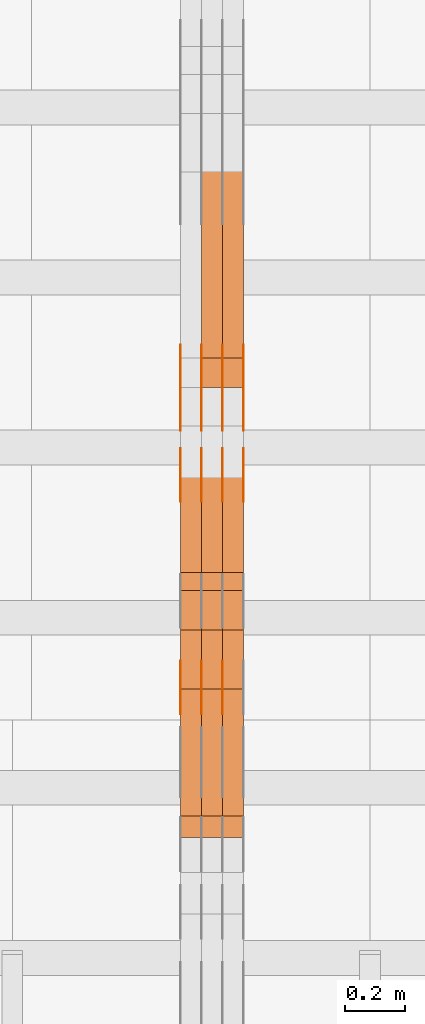
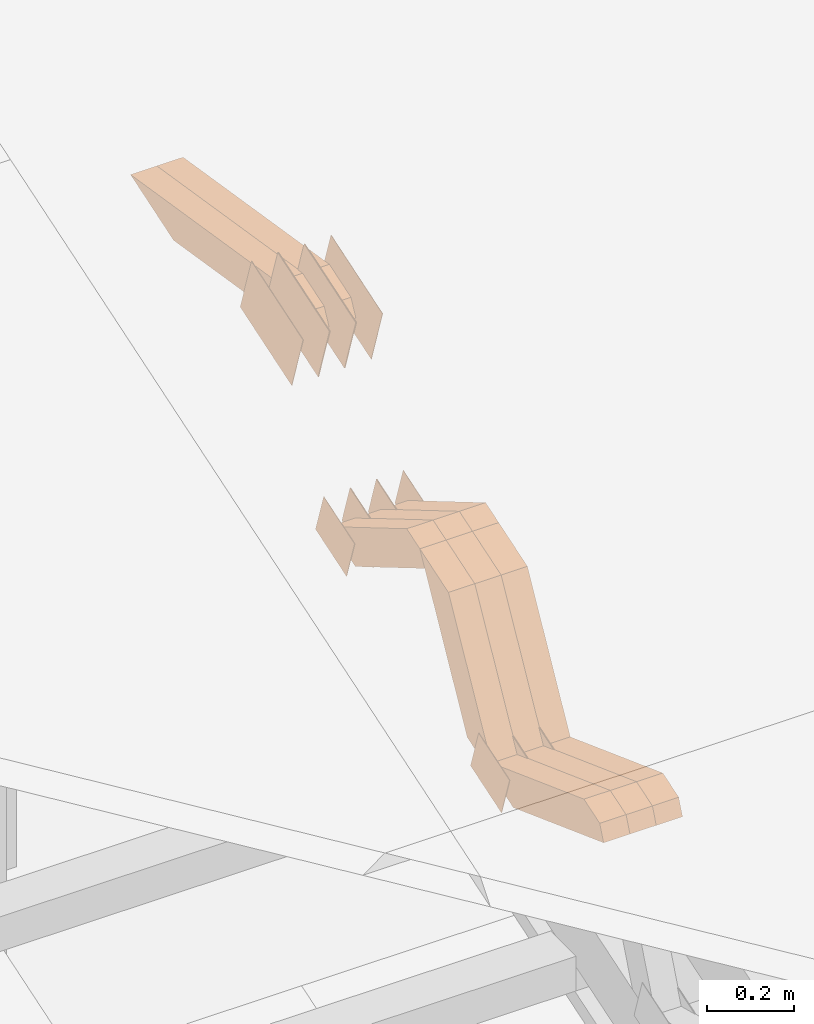
# One storey, part 52 of 385: 28 proxies.
"""IFC2X3 building model written with IfcOpenShell, lengths in millimetres."""

from ifc_helpers import new_model, entity, si_unit, converted_unit, derived_unit, direction, frame, origin, place, context, subcontext, project, spatial, polyline, outline, extrude, source, transform, mapped, material, type_object, type_shapes, element, save


model = new_model("IFC2X3")

# Units and contexts
model_context = context("Model", 3, precision=0.01, world=origin(), true_north=direction((6.12303176911189e-17, 1.0)))
body_context = subcontext(model_context, "Body", "Model", "MODEL_VIEW")
ifc_project = project(units=[si_unit("LENGTHUNIT", "METRE", prefix="MILLI"), si_unit("AREAUNIT", "SQUARE_METRE"), si_unit("VOLUMEUNIT", "CUBIC_METRE"), converted_unit("PLANEANGLEUNIT", "DEGREE", entity("IfcRatioMeasure", 0.0174532925199433), si_unit("PLANEANGLEUNIT", "RADIAN"), dimensions=[0, 0, 0, 0, 0, 0, 0]), si_unit("MASSUNIT", "GRAM", prefix="KILO"), derived_unit("MASSDENSITYUNIT", [(si_unit("MASSUNIT", "GRAM", prefix="KILO"), 1), (si_unit("LENGTHUNIT", "METRE"), -3)]), si_unit("TIMEUNIT", "SECOND"), si_unit("FREQUENCYUNIT", "HERTZ"), si_unit("THERMODYNAMICTEMPERATUREUNIT", "DEGREE_CELSIUS"), derived_unit("THERMALTRANSMITTANCEUNIT", [(si_unit("MASSUNIT", "GRAM", prefix="KILO"), 1), (si_unit("THERMODYNAMICTEMPERATUREUNIT", "KELVIN"), -1), (si_unit("TIMEUNIT", "SECOND"), -3)]), derived_unit("VOLUMETRICFLOWRATEUNIT", [(si_unit("LENGTHUNIT", "METRE"), 3), (si_unit("TIMEUNIT", "SECOND"), -1)]), si_unit("ELECTRICCURRENTUNIT", "AMPERE"), si_unit("ELECTRICVOLTAGEUNIT", "VOLT"), si_unit("POWERUNIT", "WATT"), si_unit("FORCEUNIT", "NEWTON", prefix="KILO"), si_unit("ILLUMINANCEUNIT", "LUX"), si_unit("LUMINOUSFLUXUNIT", "LUMEN"), si_unit("LUMINOUSINTENSITYUNIT", "CANDELA"), derived_unit("USERDEFINED", [(si_unit("MASSUNIT", "GRAM", prefix="KILO"), -1), (si_unit("LENGTHUNIT", "METRE"), -2), (si_unit("TIMEUNIT", "SECOND"), 3), (si_unit("LUMINOUSFLUXUNIT", "LUMEN"), 1)]), derived_unit("LINEARVELOCITYUNIT", [(si_unit("LENGTHUNIT", "METRE"), 1), (si_unit("TIMEUNIT", "SECOND"), -1)]), si_unit("PRESSUREUNIT", "PASCAL"), derived_unit("USERDEFINED", [(si_unit("LENGTHUNIT", "METRE"), -2), (si_unit("MASSUNIT", "GRAM", prefix="KILO"), 1), (si_unit("TIMEUNIT", "SECOND"), -2)])], contexts=[model_context])

# Site, building, storey
site_placement = place(None, origin())
site = spatial("IfcSite", under=ifc_project, at=site_placement, CompositionType="ELEMENT")
building_placement = place(site_placement, origin())
building = spatial("IfcBuilding", under=site, at=building_placement, CompositionType="ELEMENT")
storey_placement = place(building_placement, origin())
storey = spatial("IfcBuildingStorey", under=building, at=storey_placement, Name="Default", CompositionType="ELEMENT", Elevation=0.0)

# Proxies
ifc_material_1 = material(Name="IfcSurfaceStyle #106813")
building_element_proxy_type_1 = type_object("IfcBuildingElementProxyType", PredefinedType="NOTDEFINED", material=ifc_material_1)
shared_shape_1 = source(origin(), body_context, "Body", "SweptSolid", [
    extrude(outline(polyline([(-75.0008041947458, -59.9996998629349), (75.0007893252423, -59.9996998629349), (75.0008041947458, 59.9996998629349), (-75.0007893252423, 59.9996998629349), (-75.0008041947458, -59.9996998629349)])), frame((75.0008041947458, 60.0002282421692, 0.0), z_axis=(0.0, 0.0, 1.0), x_axis=(-1.0, 0.0, 0.0)), (0.0, 0.0, 1.0), 1.3),
])
type_shapes(building_element_proxy_type_1, [shared_shape_1])
proxy_1_placement = place(building_placement, frame((6315.0, 9291.048828125, 2194.94482421875), z_axis=(-1.0, 0.0, 0.0), x_axis=(0.0, 0.951056516295124, 0.309016994375039)))
element("IfcBuildingElementProxy", 1, at=proxy_1_placement, inside=storey, type_object=building_element_proxy_type_1, material=ifc_material_1, context=body_context, shape_type="MappedRepresentation", body=[
    mapped(shared_shape_1, transform((0.0, 0.0, 0.0), scale=1.0)),
])
ifc_material_2 = material(Name="IfcSurfaceStyle #106756")
building_element_proxy_type_2 = type_object("IfcBuildingElementProxyType", PredefinedType="NOTDEFINED", material=ifc_material_2)
shared_shape_2 = source(origin(), body_context, "Body", "SweptSolid", [
    extrude(outline(polyline([(-75.0008041947458, -59.9996998629349), (75.0007893252423, -59.9996998629349), (75.0008041947458, 59.9996998629349), (-75.0007893252423, 59.9996998629349), (-75.0008041947458, -59.9996998629349)])), frame((75.0008041947458, 60.0002282421692, 0.0), z_axis=(0.0, 0.0, 1.0), x_axis=(-1.0, 0.0, 0.0)), (0.0, 0.0, 1.0), 1.3),
])
type_shapes(building_element_proxy_type_2, [shared_shape_2])
proxy_2_placement = place(building_placement, frame((6316.29999999999, 9291.048828125, 2194.94482421875), z_axis=(-1.0, 0.0, 0.0), x_axis=(0.0, 0.951056516295124, 0.309016994375039)))
element("IfcBuildingElementProxy", 2, at=proxy_2_placement, inside=storey, type_object=building_element_proxy_type_2, material=ifc_material_2, context=body_context, shape_type="MappedRepresentation", body=[
    mapped(shared_shape_2, transform((0.0, 0.0, 0.0), scale=1.0)),
])
ifc_material_3 = material(Name="IfcSurfaceStyle #106699")
building_element_proxy_type_3 = type_object("IfcBuildingElementProxyType", PredefinedType="NOTDEFINED", material=ifc_material_3)
shared_shape_3 = source(origin(), body_context, "Body", "SweptSolid", [
    extrude(outline(polyline([(-75.0008041947458, -59.9996998629349), (75.0007893252423, -59.9996998629349), (75.0008041947458, 59.9996998629349), (-75.0007893252423, 59.9996998629349), (-75.0008041947458, -59.9996998629349)])), frame((75.0008041947458, 60.0002282421692, 0.0), z_axis=(0.0, 0.0, 1.0), x_axis=(-1.0, 0.0, 0.0)), (0.0, 0.0, 1.0), 1.29999999999999),
])
type_shapes(building_element_proxy_type_3, [shared_shape_3])
proxy_3_placement = place(building_placement, frame((6245.0, 9291.048828125, 2194.94482421875), z_axis=(-1.0, 0.0, 0.0), x_axis=(0.0, 0.951056516295124, 0.309016994375039)))
element("IfcBuildingElementProxy", 3, at=proxy_3_placement, inside=storey, type_object=building_element_proxy_type_3, material=ifc_material_3, context=body_context, shape_type="MappedRepresentation", body=[
    mapped(shared_shape_3, transform((0.0, 0.0, 0.0), scale=1.0)),
])
ifc_material_4 = material(Name="IfcSurfaceStyle #106642")
building_element_proxy_type_4 = type_object("IfcBuildingElementProxyType", PredefinedType="NOTDEFINED", material=ifc_material_4)
shared_shape_4 = source(origin(), body_context, "Body", "SweptSolid", [
    extrude(outline(polyline([(-75.0008041947458, -59.9996998629349), (75.0007893252423, -59.9996998629349), (75.0008041947458, 59.9996998629349), (-75.0007893252423, 59.9996998629349), (-75.0008041947458, -59.9996998629349)])), frame((75.0008041947458, 60.0002282421692, 0.0), z_axis=(0.0, 0.0, 1.0), x_axis=(-1.0, 0.0, 0.0)), (0.0, 0.0, 1.0), 1.29999999999999),
])
type_shapes(building_element_proxy_type_4, [shared_shape_4])
proxy_4_placement = place(building_placement, frame((6246.29999999999, 9291.048828125, 2194.94482421875), z_axis=(-1.0, 0.0, 0.0), x_axis=(0.0, 0.951056516295124, 0.309016994375039)))
element("IfcBuildingElementProxy", 4, at=proxy_4_placement, inside=storey, type_object=building_element_proxy_type_4, material=ifc_material_4, context=body_context, shape_type="MappedRepresentation", body=[
    mapped(shared_shape_4, transform((0.0, 0.0, 0.0), scale=1.0)),
])
ifc_material_5 = material(Name="IfcSurfaceStyle #106585")
building_element_proxy_type_5 = type_object("IfcBuildingElementProxyType", PredefinedType="NOTDEFINED", material=ifc_material_5)
shared_shape_5 = source(origin(), body_context, "Body", "SweptSolid", [
    extrude(outline(polyline([(-75.0008041947458, -59.9996998629349), (75.0007893252423, -59.9996998629349), (75.0008041947458, 59.9996998629349), (-75.0007893252423, 59.9996998629349), (-75.0008041947458, -59.9996998629349)])), frame((75.0008041947458, 60.0002282421692, 0.0), z_axis=(0.0, 0.0, 1.0), x_axis=(-1.0, 0.0, 0.0)), (0.0, 0.0, 1.0), 1.29999999999999),
])
type_shapes(building_element_proxy_type_5, [shared_shape_5])
proxy_5_placement = place(building_placement, frame((6175.0, 9291.048828125, 2194.94482421875), z_axis=(-1.0, 0.0, 0.0), x_axis=(0.0, 0.951056516295124, 0.309016994375039)))
element("IfcBuildingElementProxy", 5, at=proxy_5_placement, inside=storey, type_object=building_element_proxy_type_5, material=ifc_material_5, context=body_context, shape_type="MappedRepresentation", body=[
    mapped(shared_shape_5, transform((0.0, 0.0, 0.0), scale=1.0)),
])
ifc_material_6 = material(Name="IfcSurfaceStyle #106528")
building_element_proxy_type_6 = type_object("IfcBuildingElementProxyType", PredefinedType="NOTDEFINED", material=ifc_material_6)
shared_shape_6 = source(origin(), body_context, "Body", "SweptSolid", [
    extrude(outline(polyline([(-124.999432723313, -83.9999457831645), (125.000177551971, -83.9999457831645), (124.999395001513, 83.9999457831646), (-125.000139830171, 83.9999457831645), (-124.999432723313, -83.9999457831645)])), frame((125.000177551971, 84.0001194377192, 0.0), z_axis=(0.0, 0.0, 1.0), x_axis=(-1.0, 0.0, 0.0)), (0.0, 0.0, 1.0), 1.3),
])
type_shapes(building_element_proxy_type_6, [shared_shape_6])
proxy_6_placement = place(building_placement, frame((6386.29999999999, 10242.0968435407, 2855.88278137571), z_axis=(-1.0, 0.0, 0.0), x_axis=(0.0, 0.951056516295154, 0.309016994374948)))
element("IfcBuildingElementProxy", 6, at=proxy_6_placement, inside=storey, type_object=building_element_proxy_type_6, material=ifc_material_6, context=body_context, shape_type="MappedRepresentation", body=[
    mapped(shared_shape_6, transform((0.0, 0.0, 0.0), scale=1.0)),
])
ifc_material_7 = material(Name="IfcSurfaceStyle #106471")
building_element_proxy_type_7 = type_object("IfcBuildingElementProxyType", PredefinedType="NOTDEFINED", material=ifc_material_7)
shared_shape_7 = source(origin(), body_context, "Body", "SweptSolid", [
    extrude(outline(polyline([(-124.999432723313, -83.9999457831645), (125.000177551971, -83.9999457831645), (124.999395001513, 83.9999457831646), (-125.000139830171, 83.9999457831645), (-124.999432723313, -83.9999457831645)])), frame((125.000177551971, 84.0001194377192, 0.0), z_axis=(0.0, 0.0, 1.0), x_axis=(-1.0, 0.0, 0.0)), (0.0, 0.0, 1.0), 1.3),
])
type_shapes(building_element_proxy_type_7, [shared_shape_7])
proxy_7_placement = place(building_placement, frame((6315.0, 10242.0968435407, 2855.88278137571), z_axis=(-1.0, 0.0, 0.0), x_axis=(0.0, 0.951056516295154, 0.309016994374948)))
element("IfcBuildingElementProxy", 7, at=proxy_7_placement, inside=storey, type_object=building_element_proxy_type_7, material=ifc_material_7, context=body_context, shape_type="MappedRepresentation", body=[
    mapped(shared_shape_7, transform((0.0, 0.0, 0.0), scale=1.0)),
])
ifc_material_8 = material(Name="IfcSurfaceStyle #106414")
building_element_proxy_type_8 = type_object("IfcBuildingElementProxyType", PredefinedType="NOTDEFINED", material=ifc_material_8)
shared_shape_8 = source(origin(), body_context, "Body", "SweptSolid", [
    extrude(outline(polyline([(-124.999432723313, -83.9999457831645), (125.000177551971, -83.9999457831645), (124.999395001513, 83.9999457831646), (-125.000139830171, 83.9999457831645), (-124.999432723313, -83.9999457831645)])), frame((125.000177551971, 84.0001194377192, 0.0), z_axis=(0.0, 0.0, 1.0), x_axis=(-1.0, 0.0, 0.0)), (0.0, 0.0, 1.0), 1.3),
])
type_shapes(building_element_proxy_type_8, [shared_shape_8])
proxy_8_placement = place(building_placement, frame((6316.29999999999, 10242.0968435407, 2855.88278137571), z_axis=(-1.0, 0.0, 0.0), x_axis=(0.0, 0.951056516295154, 0.309016994374948)))
element("IfcBuildingElementProxy", 8, at=proxy_8_placement, inside=storey, type_object=building_element_proxy_type_8, material=ifc_material_8, context=body_context, shape_type="MappedRepresentation", body=[
    mapped(shared_shape_8, transform((0.0, 0.0, 0.0), scale=1.0)),
])
ifc_material_9 = material(Name="IfcSurfaceStyle #106357")
building_element_proxy_type_9 = type_object("IfcBuildingElementProxyType", PredefinedType="NOTDEFINED", material=ifc_material_9)
shared_shape_9 = source(origin(), body_context, "Body", "SweptSolid", [
    extrude(outline(polyline([(-124.999432723313, -83.9999457831645), (125.000177551971, -83.9999457831645), (124.999395001513, 83.9999457831646), (-125.000139830171, 83.9999457831645), (-124.999432723313, -83.9999457831645)])), frame((125.000177551971, 84.0001194377192, 0.0), z_axis=(0.0, 0.0, 1.0), x_axis=(-1.0, 0.0, 0.0)), (0.0, 0.0, 1.0), 1.29999999999998),
])
type_shapes(building_element_proxy_type_9, [shared_shape_9])
proxy_9_placement = place(building_placement, frame((6245.0, 10242.0968435407, 2855.88278137571), z_axis=(-1.0, 0.0, 0.0), x_axis=(0.0, 0.951056516295154, 0.309016994374948)))
element("IfcBuildingElementProxy", 9, at=proxy_9_placement, inside=storey, type_object=building_element_proxy_type_9, material=ifc_material_9, context=body_context, shape_type="MappedRepresentation", body=[
    mapped(shared_shape_9, transform((0.0, 0.0, 0.0), scale=1.0)),
])
ifc_material_10 = material(Name="IfcSurfaceStyle #106300")
building_element_proxy_type_10 = type_object("IfcBuildingElementProxyType", PredefinedType="NOTDEFINED", material=ifc_material_10)
shared_shape_10 = source(origin(), body_context, "Body", "SweptSolid", [
    extrude(outline(polyline([(-124.999432723313, -83.9999457831645), (125.000177551971, -83.9999457831645), (124.999395001513, 83.9999457831646), (-125.000139830171, 83.9999457831645), (-124.999432723313, -83.9999457831645)])), frame((125.000177551971, 84.0001194377192, 0.0), z_axis=(0.0, 0.0, 1.0), x_axis=(-1.0, 0.0, 0.0)), (0.0, 0.0, 1.0), 1.29999999999998),
])
type_shapes(building_element_proxy_type_10, [shared_shape_10])
proxy_10_placement = place(building_placement, frame((6246.29999999999, 10242.0968435407, 2855.88278137571), z_axis=(-1.0, 0.0, 0.0), x_axis=(0.0, 0.951056516295154, 0.309016994374948)))
element("IfcBuildingElementProxy", 10, at=proxy_10_placement, inside=storey, type_object=building_element_proxy_type_10, material=ifc_material_10, context=body_context, shape_type="MappedRepresentation", body=[
    mapped(shared_shape_10, transform((0.0, 0.0, 0.0), scale=1.0)),
])
ifc_material_11 = material(Name="IfcSurfaceStyle #106243")
building_element_proxy_type_11 = type_object("IfcBuildingElementProxyType", PredefinedType="NOTDEFINED", material=ifc_material_11)
shared_shape_11 = source(origin(), body_context, "Body", "SweptSolid", [
    extrude(outline(polyline([(-124.999432723313, -83.9999457831645), (125.000177551971, -83.9999457831645), (124.999395001513, 83.9999457831646), (-125.000139830171, 83.9999457831645), (-124.999432723313, -83.9999457831645)])), frame((125.000177551971, 84.0001194377192, 0.0), z_axis=(0.0, 0.0, 1.0), x_axis=(-1.0, 0.0, 0.0)), (0.0, 0.0, 1.0), 1.29999999999998),
])
type_shapes(building_element_proxy_type_11, [shared_shape_11])
proxy_11_placement = place(building_placement, frame((6175.0, 10242.0968435407, 2855.88278137571), z_axis=(-1.0, 0.0, 0.0), x_axis=(0.0, 0.951056516295154, 0.309016994374948)))
element("IfcBuildingElementProxy", 11, at=proxy_11_placement, inside=storey, type_object=building_element_proxy_type_11, material=ifc_material_11, context=body_context, shape_type="MappedRepresentation", body=[
    mapped(shared_shape_11, transform((0.0, 0.0, 0.0), scale=1.0)),
])
ifc_material_12 = material(Name="IfcSurfaceStyle #104818")
building_element_proxy_type_12 = type_object("IfcBuildingElementProxyType", PredefinedType="NOTDEFINED", material=ifc_material_12)
shared_shape_12 = source(origin(), body_context, "Body", "SweptSolid", [
    extrude(outline(polyline([(-74.9998754286189, -60.0000016373433), (74.9998605591118, -60.0000016373433), (74.9998754286189, 60.0000016373433), (-74.9998605591118, 60.0000016373433), (-74.9998754286189, -60.0000016373433)])), frame((74.9999131819004, 60.0000016373433, 0.0), z_axis=(0.0, 0.0, 1.0), x_axis=(-1.0, 0.0, 0.0)), (0.0, 0.0, 1.0), 1.3),
])
type_shapes(building_element_proxy_type_12, [shared_shape_12])
proxy_12_placement = place(building_placement, frame((6386.29999999999, 10004.8612689908, 2426.87628052724), z_axis=(-1.0, 0.0, 0.0), x_axis=(0.0, 0.951056516295124, 0.309016994375039)))
element("IfcBuildingElementProxy", 12, at=proxy_12_placement, inside=storey, type_object=building_element_proxy_type_12, material=ifc_material_12, context=body_context, shape_type="MappedRepresentation", body=[
    mapped(shared_shape_12, transform((0.0, 0.0, 0.0), scale=1.0)),
])
ifc_material_13 = material(Name="IfcSurfaceStyle #104761")
building_element_proxy_type_13 = type_object("IfcBuildingElementProxyType", PredefinedType="NOTDEFINED", material=ifc_material_13)
shared_shape_13 = source(origin(), body_context, "Body", "SweptSolid", [
    extrude(outline(polyline([(-74.9998754286189, -60.0000016373433), (74.9998605591118, -60.0000016373433), (74.9998754286189, 60.0000016373433), (-74.9998605591118, 60.0000016373433), (-74.9998754286189, -60.0000016373433)])), frame((74.9999131819004, 60.0000016373433, 0.0), z_axis=(0.0, 0.0, 1.0), x_axis=(-1.0, 0.0, 0.0)), (0.0, 0.0, 1.0), 1.3),
])
type_shapes(building_element_proxy_type_13, [shared_shape_13])
proxy_13_placement = place(building_placement, frame((6315.0, 10004.8612689908, 2426.87628052724), z_axis=(-1.0, 0.0, 0.0), x_axis=(0.0, 0.951056516295124, 0.309016994375039)))
element("IfcBuildingElementProxy", 13, at=proxy_13_placement, inside=storey, type_object=building_element_proxy_type_13, material=ifc_material_13, context=body_context, shape_type="MappedRepresentation", body=[
    mapped(shared_shape_13, transform((0.0, 0.0, 0.0), scale=1.0)),
])
ifc_material_14 = material(Name="IfcSurfaceStyle #104704")
building_element_proxy_type_14 = type_object("IfcBuildingElementProxyType", PredefinedType="NOTDEFINED", material=ifc_material_14)
shared_shape_14 = source(origin(), body_context, "Body", "SweptSolid", [
    extrude(outline(polyline([(-74.9998754286189, -60.0000016373433), (74.9998605591118, -60.0000016373433), (74.9998754286189, 60.0000016373433), (-74.9998605591118, 60.0000016373433), (-74.9998754286189, -60.0000016373433)])), frame((74.9999131819004, 60.0000016373433, 0.0), z_axis=(0.0, 0.0, 1.0), x_axis=(-1.0, 0.0, 0.0)), (0.0, 0.0, 1.0), 1.3),
])
type_shapes(building_element_proxy_type_14, [shared_shape_14])
proxy_14_placement = place(building_placement, frame((6316.29999999999, 10004.8612689908, 2426.87628052724), z_axis=(-1.0, 0.0, 0.0), x_axis=(0.0, 0.951056516295124, 0.309016994375039)))
element("IfcBuildingElementProxy", 14, at=proxy_14_placement, inside=storey, type_object=building_element_proxy_type_14, material=ifc_material_14, context=body_context, shape_type="MappedRepresentation", body=[
    mapped(shared_shape_14, transform((0.0, 0.0, 0.0), scale=1.0)),
])
ifc_material_15 = material(Name="IfcSurfaceStyle #104647")
building_element_proxy_type_15 = type_object("IfcBuildingElementProxyType", PredefinedType="NOTDEFINED", material=ifc_material_15)
shared_shape_15 = source(origin(), body_context, "Body", "SweptSolid", [
    extrude(outline(polyline([(-74.9998754286189, -60.0000016373433), (74.9998605591118, -60.0000016373433), (74.9998754286189, 60.0000016373433), (-74.9998605591118, 60.0000016373433), (-74.9998754286189, -60.0000016373433)])), frame((74.9999131819004, 60.0000016373433, 0.0), z_axis=(0.0, 0.0, 1.0), x_axis=(-1.0, 0.0, 0.0)), (0.0, 0.0, 1.0), 1.29999999999999),
])
type_shapes(building_element_proxy_type_15, [shared_shape_15])
proxy_15_placement = place(building_placement, frame((6245.0, 10004.8612689908, 2426.87628052724), z_axis=(-1.0, 0.0, 0.0), x_axis=(0.0, 0.951056516295124, 0.309016994375039)))
element("IfcBuildingElementProxy", 15, at=proxy_15_placement, inside=storey, type_object=building_element_proxy_type_15, material=ifc_material_15, context=body_context, shape_type="MappedRepresentation", body=[
    mapped(shared_shape_15, transform((0.0, 0.0, 0.0), scale=1.0)),
])
ifc_material_16 = material(Name="IfcSurfaceStyle #104590")
building_element_proxy_type_16 = type_object("IfcBuildingElementProxyType", PredefinedType="NOTDEFINED", material=ifc_material_16)
shared_shape_16 = source(origin(), body_context, "Body", "SweptSolid", [
    extrude(outline(polyline([(-74.9998754286189, -60.0000016373433), (74.9998605591118, -60.0000016373433), (74.9998754286189, 60.0000016373433), (-74.9998605591118, 60.0000016373433), (-74.9998754286189, -60.0000016373433)])), frame((74.9999131819004, 60.0000016373433, 0.0), z_axis=(0.0, 0.0, 1.0), x_axis=(-1.0, 0.0, 0.0)), (0.0, 0.0, 1.0), 1.29999999999999),
])
type_shapes(building_element_proxy_type_16, [shared_shape_16])
proxy_16_placement = place(building_placement, frame((6246.29999999999, 10004.8612689908, 2426.87628052724), z_axis=(-1.0, 0.0, 0.0), x_axis=(0.0, 0.951056516295124, 0.309016994375039)))
element("IfcBuildingElementProxy", 16, at=proxy_16_placement, inside=storey, type_object=building_element_proxy_type_16, material=ifc_material_16, context=body_context, shape_type="MappedRepresentation", body=[
    mapped(shared_shape_16, transform((0.0, 0.0, 0.0), scale=1.0)),
])
ifc_material_17 = material(Name="IfcSurfaceStyle #104533")
building_element_proxy_type_17 = type_object("IfcBuildingElementProxyType", PredefinedType="NOTDEFINED", material=ifc_material_17)
shared_shape_17 = source(origin(), body_context, "Body", "SweptSolid", [
    extrude(outline(polyline([(-74.9998754286189, -60.0000016373433), (74.9998605591118, -60.0000016373433), (74.9998754286189, 60.0000016373433), (-74.9998605591118, 60.0000016373433), (-74.9998754286189, -60.0000016373433)])), frame((74.9999131819004, 60.0000016373433, 0.0), z_axis=(0.0, 0.0, 1.0), x_axis=(-1.0, 0.0, 0.0)), (0.0, 0.0, 1.0), 1.29999999999999),
])
type_shapes(building_element_proxy_type_17, [shared_shape_17])
proxy_17_placement = place(building_placement, frame((6175.0, 10004.8612689908, 2426.87628052724), z_axis=(-1.0, 0.0, 0.0), x_axis=(0.0, 0.951056516295124, 0.309016994375039)))
element("IfcBuildingElementProxy", 17, at=proxy_17_placement, inside=storey, type_object=building_element_proxy_type_17, material=ifc_material_17, context=body_context, shape_type="MappedRepresentation", body=[
    mapped(shared_shape_17, transform((0.0, 0.0, 0.0), scale=1.0)),
])
ifc_material_18 = material(Name="IfcSurfaceStyle #84496")
building_element_proxy_type_18 = type_object("IfcBuildingElementProxyType", Name="T1-W5 84494", PredefinedType="NOTDEFINED", material=ifc_material_18)
shared_shape_18 = source(origin(), body_context, "Body", "SweptSolid", [
    extrude(outline(polyline([(-301.214270081322, -47.5000783565111), (303.980395954293, -47.5000783565111), (288.664123931657, 0.000197935560590153), (195.704076557203, 47.4999793887309), (-487.134326361831, 47.4999793887309), (-301.214270081322, -47.5000783565111)])), frame((303.980395954293, 47.5001815410909, 0.0), z_axis=(0.0, 0.0, 1.0), x_axis=(-1.0, 0.0, 0.0)), (0.0, 0.0, 1.0), 70.0),
])
type_shapes(building_element_proxy_type_18, [shared_shape_18])
proxy_18_placement = place(building_placement, frame((6385.0, 10379.2051671398, 2863.91176079486), z_axis=(-1.0, 0.0, 0.0), x_axis=(0.0, 0.987508363398486, -0.1575665961365)))
element("IfcBuildingElementProxy", 18, at=proxy_18_placement, inside=storey, type_object=building_element_proxy_type_18, material=ifc_material_18, Name="T1-W5", context=body_context, shape_type="MappedRepresentation", body=[
    mapped(shared_shape_18, transform((0.0, 0.0, 0.0), scale=1.0)),
])
ifc_material_19 = material(Name="IfcSurfaceStyle #84430")
building_element_proxy_type_19 = type_object("IfcBuildingElementProxyType", Name="T1-W5 84428", PredefinedType="NOTDEFINED", material=ifc_material_19)
shared_shape_19 = source(origin(), body_context, "Body", "SweptSolid", [
    extrude(outline(polyline([(-301.214270081322, -47.5000783565111), (303.980395954293, -47.5000783565111), (288.664123931657, 0.000197935560590153), (195.704076557203, 47.4999793887309), (-487.134326361831, 47.4999793887309), (-301.214270081322, -47.5000783565111)])), frame((303.980395954293, 47.5001815410909, 0.0), z_axis=(0.0, 0.0, 1.0), x_axis=(-1.0, 0.0, 0.0)), (0.0, 0.0, 1.0), 70.0),
])
type_shapes(building_element_proxy_type_19, [shared_shape_19])
proxy_19_placement = place(building_placement, frame((6315.0, 10379.2051671398, 2863.91176079486), z_axis=(-1.0, 0.0, 0.0), x_axis=(0.0, 0.987508363398486, -0.1575665961365)))
element("IfcBuildingElementProxy", 19, at=proxy_19_placement, inside=storey, type_object=building_element_proxy_type_19, material=ifc_material_19, Name="T1-W5", context=body_context, shape_type="MappedRepresentation", body=[
    mapped(shared_shape_19, transform((0.0, 0.0, 0.0), scale=1.0)),
])
ifc_material_20 = material(Name="IfcSurfaceStyle #83704")
building_element_proxy_type_20 = type_object("IfcBuildingElementProxyType", Name="T1-W43 83702", PredefinedType="NOTDEFINED", material=ifc_material_20)
shared_shape_20 = source(origin(), body_context, "Body", "SweptSolid", [
    extrude(outline(polyline([(-198.159905426436, -47.4999961988362), (173.155878681738, -47.4999961988362), (174.585865234707, -0.00038778214839239), (132.582704932703, 47.5001900899104), (-282.164543422712, 47.5001900899104), (-198.159905426436, -47.4999961988362)])), frame((174.585865234707, 47.5001900899104, 0.0), z_axis=(0.0, 0.0, 1.0), x_axis=(-1.0, 0.0, 0.0)), (0.0, 0.0, 1.0), 70.0),
])
type_shapes(building_element_proxy_type_20, [shared_shape_20])
proxy_20_placement = place(building_placement, frame((6385.0, 9730.71877771152, 2634.4881681647), z_axis=(-1.0, 0.0, 0.0), x_axis=(0.0, 0.861495156633645, -0.507765787639115)))
element("IfcBuildingElementProxy", 20, at=proxy_20_placement, inside=storey, type_object=building_element_proxy_type_20, material=ifc_material_20, Name="T1-W43", context=body_context, shape_type="MappedRepresentation", body=[
    mapped(shared_shape_20, transform((0.0, 0.0, 0.0), scale=1.0)),
])
ifc_material_21 = material(Name="IfcSurfaceStyle #83638")
building_element_proxy_type_21 = type_object("IfcBuildingElementProxyType", Name="T1-W43 83636", PredefinedType="NOTDEFINED", material=ifc_material_21)
shared_shape_21 = source(origin(), body_context, "Body", "SweptSolid", [
    extrude(outline(polyline([(-198.159905426436, -47.4999961988362), (173.155878681738, -47.4999961988362), (174.585865234707, -0.00038778214839239), (132.582704932703, 47.5001900899104), (-282.164543422712, 47.5001900899104), (-198.159905426436, -47.4999961988362)])), frame((174.585865234707, 47.5001900899104, 0.0), z_axis=(0.0, 0.0, 1.0), x_axis=(-1.0, 0.0, 0.0)), (0.0, 0.0, 1.0), 70.0),
])
type_shapes(building_element_proxy_type_21, [shared_shape_21])
proxy_21_placement = place(building_placement, frame((6315.0, 9730.71877771152, 2634.4881681647), z_axis=(-1.0, 0.0, 0.0), x_axis=(0.0, 0.861495156633645, -0.507765787639115)))
element("IfcBuildingElementProxy", 21, at=proxy_21_placement, inside=storey, type_object=building_element_proxy_type_21, material=ifc_material_21, Name="T1-W43", context=body_context, shape_type="MappedRepresentation", body=[
    mapped(shared_shape_21, transform((0.0, 0.0, 0.0), scale=1.0)),
])
ifc_material_22 = material(Name="IfcSurfaceStyle #83572")
building_element_proxy_type_22 = type_object("IfcBuildingElementProxyType", Name="T1-W43 83570", PredefinedType="NOTDEFINED", material=ifc_material_22)
shared_shape_22 = source(origin(), body_context, "Body", "SweptSolid", [
    extrude(outline(polyline([(-198.159905426436, -47.4999961988362), (173.155878681738, -47.4999961988362), (174.585865234707, -0.00038778214839239), (132.582704932703, 47.5001900899104), (-282.164543422712, 47.5001900899104), (-198.159905426436, -47.4999961988362)])), frame((174.585865234707, 47.5001900899104, 0.0), z_axis=(0.0, 0.0, 1.0), x_axis=(-1.0, 0.0, 0.0)), (0.0, 0.0, 1.0), 70.0),
])
type_shapes(building_element_proxy_type_22, [shared_shape_22])
proxy_22_placement = place(building_placement, frame((6245.0, 9730.71877771152, 2634.4881681647), z_axis=(-1.0, 0.0, 0.0), x_axis=(0.0, 0.861495156633645, -0.507765787639115)))
element("IfcBuildingElementProxy", 22, at=proxy_22_placement, inside=storey, type_object=building_element_proxy_type_22, material=ifc_material_22, Name="T1-W43", context=body_context, shape_type="MappedRepresentation", body=[
    mapped(shared_shape_22, transform((0.0, 0.0, 0.0), scale=1.0)),
])
ifc_material_23 = material(Name="IfcSurfaceStyle #83308")
building_element_proxy_type_23 = type_object("IfcBuildingElementProxyType", Name="T1-W33 83306", PredefinedType="NOTDEFINED", material=ifc_material_23)
shared_shape_23 = source(origin(), body_context, "Body", "SweptSolid", [
    extrude(outline(polyline([(-314.173070820175, -47.4997758466969), (139.635944117881, -47.4997758466969), (190.204920608233, 0.000348187720347082), (197.369205310989, 47.5001702328475), (-213.036999216928, 47.4990332728259), (-314.173070820175, -47.4997758466969)])), frame((197.369205310989, 47.5001702328475, 0.0), z_axis=(0.0, 0.0, 1.0), x_axis=(-1.0, 0.0, 0.0)), (0.0, 0.0, 1.0), 70.0),
])
type_shapes(building_element_proxy_type_23, [shared_shape_23])
proxy_23_placement = place(building_placement, frame((6385.0, 9376.96875, 2191.01977539063), z_axis=(-1.0, 0.0, 0.0), x_axis=(0.0, 0.481632628948835, 0.876373214293907)))
element("IfcBuildingElementProxy", 23, at=proxy_23_placement, inside=storey, type_object=building_element_proxy_type_23, material=ifc_material_23, Name="T1-W33", context=body_context, shape_type="MappedRepresentation", body=[
    mapped(shared_shape_23, transform((0.0, 0.0, 0.0), scale=1.0)),
])
ifc_material_24 = material(Name="IfcSurfaceStyle #83242")
building_element_proxy_type_24 = type_object("IfcBuildingElementProxyType", Name="T1-W33 83240", PredefinedType="NOTDEFINED", material=ifc_material_24)
shared_shape_24 = source(origin(), body_context, "Body", "SweptSolid", [
    extrude(outline(polyline([(-314.173070820175, -47.4997758466969), (139.635944117881, -47.4997758466969), (190.204920608233, 0.000348187720347082), (197.369205310989, 47.5001702328475), (-213.036999216928, 47.4990332728259), (-314.173070820175, -47.4997758466969)])), frame((197.369205310989, 47.5001702328475, 0.0), z_axis=(0.0, 0.0, 1.0), x_axis=(-1.0, 0.0, 0.0)), (0.0, 0.0, 1.0), 70.0),
])
type_shapes(building_element_proxy_type_24, [shared_shape_24])
proxy_24_placement = place(building_placement, frame((6315.0, 9376.96875, 2191.01977539063), z_axis=(-1.0, 0.0, 0.0), x_axis=(0.0, 0.481632628948835, 0.876373214293907)))
element("IfcBuildingElementProxy", 24, at=proxy_24_placement, inside=storey, type_object=building_element_proxy_type_24, material=ifc_material_24, Name="T1-W33", context=body_context, shape_type="MappedRepresentation", body=[
    mapped(shared_shape_24, transform((0.0, 0.0, 0.0), scale=1.0)),
])
ifc_material_25 = material(Name="IfcSurfaceStyle #83176")
building_element_proxy_type_25 = type_object("IfcBuildingElementProxyType", Name="T1-W33 83174", PredefinedType="NOTDEFINED", material=ifc_material_25)
shared_shape_25 = source(origin(), body_context, "Body", "SweptSolid", [
    extrude(outline(polyline([(-314.173070820175, -47.4997758466969), (139.635944117881, -47.4997758466969), (190.204920608233, 0.000348187720347082), (197.369205310989, 47.5001702328475), (-213.036999216928, 47.4990332728259), (-314.173070820175, -47.4997758466969)])), frame((197.369205310989, 47.5001702328475, 0.0), z_axis=(0.0, 0.0, 1.0), x_axis=(-1.0, 0.0, 0.0)), (0.0, 0.0, 1.0), 70.0),
])
type_shapes(building_element_proxy_type_25, [shared_shape_25])
proxy_25_placement = place(building_placement, frame((6245.0, 9376.96875, 2191.01977539063), z_axis=(-1.0, 0.0, 0.0), x_axis=(0.0, 0.481632628948835, 0.876373214293907)))
element("IfcBuildingElementProxy", 25, at=proxy_25_placement, inside=storey, type_object=building_element_proxy_type_25, material=ifc_material_25, Name="T1-W33", context=body_context, shape_type="MappedRepresentation", body=[
    mapped(shared_shape_25, transform((0.0, 0.0, 0.0), scale=1.0)),
])
ifc_material_26 = material(Name="IfcSurfaceStyle #82912")
building_element_proxy_type_26 = type_object("IfcBuildingElementProxyType", Name="T1-W25 82910", PredefinedType="NOTDEFINED", material=ifc_material_26)
shared_shape_26 = source(origin(), body_context, "Body", "SweptSolid", [
    extrude(outline(polyline([(-229.232772462784, -47.5001671709529), (214.075939394384, -47.5001671709529), (212.688957821661, -0.000141058964427199), (152.358910178478, 47.5002377004352), (-349.891034931738, 47.5002377004352), (-229.232772462784, -47.5001671709529)])), frame((214.075939394384, 47.5002377004352, 0.0), z_axis=(0.0, 0.0, 1.0), x_axis=(-1.0, 0.0, 0.0)), (0.0, 0.0, 1.0), 70.0),
])
type_shapes(building_element_proxy_type_26, [shared_shape_26])
proxy_26_placement = place(building_placement, frame((6385.0, 8892.81895960242, 2369.29665807578), z_axis=(-1.0, 0.0, 0.0), x_axis=(0.0, 0.938402514401222, -0.345544094097213)))
element("IfcBuildingElementProxy", 26, at=proxy_26_placement, inside=storey, type_object=building_element_proxy_type_26, material=ifc_material_26, Name="T1-W25", context=body_context, shape_type="MappedRepresentation", body=[
    mapped(shared_shape_26, transform((0.0, 0.0, 0.0), scale=1.0)),
])
ifc_material_27 = material(Name="IfcSurfaceStyle #82846")
building_element_proxy_type_27 = type_object("IfcBuildingElementProxyType", Name="T1-W25 82844", PredefinedType="NOTDEFINED", material=ifc_material_27)
shared_shape_27 = source(origin(), body_context, "Body", "SweptSolid", [
    extrude(outline(polyline([(-229.232772462784, -47.5001671709529), (214.075939394384, -47.5001671709529), (212.688957821661, -0.000141058964427199), (152.358910178478, 47.5002377004352), (-349.891034931738, 47.5002377004352), (-229.232772462784, -47.5001671709529)])), frame((214.075939394384, 47.5002377004352, 0.0), z_axis=(0.0, 0.0, 1.0), x_axis=(-1.0, 0.0, 0.0)), (0.0, 0.0, 1.0), 70.0),
])
type_shapes(building_element_proxy_type_27, [shared_shape_27])
proxy_27_placement = place(building_placement, frame((6315.0, 8892.81895960242, 2369.29665807578), z_axis=(-1.0, 0.0, 0.0), x_axis=(0.0, 0.938402514401222, -0.345544094097213)))
element("IfcBuildingElementProxy", 27, at=proxy_27_placement, inside=storey, type_object=building_element_proxy_type_27, material=ifc_material_27, Name="T1-W25", context=body_context, shape_type="MappedRepresentation", body=[
    mapped(shared_shape_27, transform((0.0, 0.0, 0.0), scale=1.0)),
])
ifc_material_28 = material(Name="IfcSurfaceStyle #82780")
building_element_proxy_type_28 = type_object("IfcBuildingElementProxyType", Name="T1-W25 82778", PredefinedType="NOTDEFINED", material=ifc_material_28)
shared_shape_28 = source(origin(), body_context, "Body", "SweptSolid", [
    extrude(outline(polyline([(-229.232772462784, -47.5001671709529), (214.075939394384, -47.5001671709529), (212.688957821661, -0.000141058964427199), (152.358910178478, 47.5002377004352), (-349.891034931738, 47.5002377004352), (-229.232772462784, -47.5001671709529)])), frame((214.075939394384, 47.5002377004352, 0.0), z_axis=(0.0, 0.0, 1.0), x_axis=(-1.0, 0.0, 0.0)), (0.0, 0.0, 1.0), 70.0),
])
type_shapes(building_element_proxy_type_28, [shared_shape_28])
proxy_28_placement = place(building_placement, frame((6245.0, 8892.81895960242, 2369.29665807578), z_axis=(-1.0, 0.0, 0.0), x_axis=(0.0, 0.938402514401222, -0.345544094097213)))
element("IfcBuildingElementProxy", 28, at=proxy_28_placement, inside=storey, type_object=building_element_proxy_type_28, material=ifc_material_28, Name="T1-W25", context=body_context, shape_type="MappedRepresentation", body=[
    mapped(shared_shape_28, transform((0.0, 0.0, 0.0), scale=1.0)),
])

save(model, "model.ifc")
